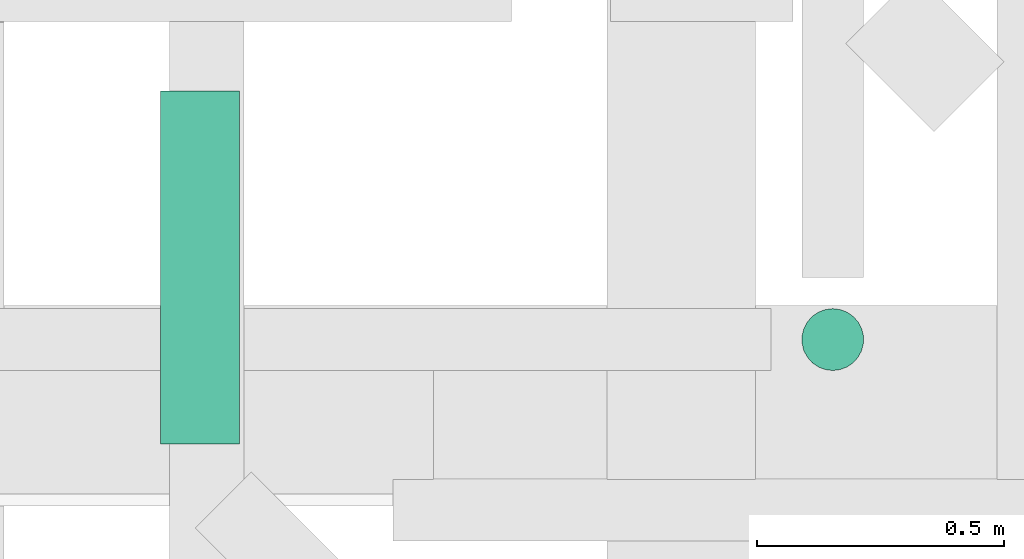
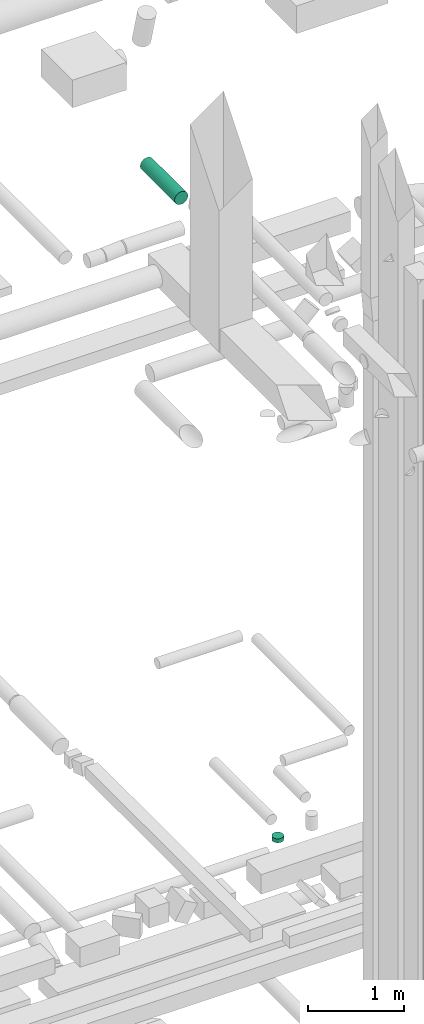
# One storey, part 283 of 337: 2 flow segments.
"""IFC2X3 building model written with IfcOpenShell, lengths in millimetres."""

from ifc_helpers import new_model, entity, si_unit, converted_unit, derived_unit, direction, frame, origin, origin_2d_with_axis, place, context, subcontext, project, spatial, circle, extrude, type_object, element, save


model = new_model("IFC2X3")

# Units and contexts
model_context = context("Model", 3, precision=0.01, world=origin(), true_north=direction((6.12303176911189e-17, 1.0)))
body_context = subcontext(model_context, "Body", "Model", "MODEL_VIEW")
ifc_project = project(units=[si_unit("LENGTHUNIT", "METRE", prefix="MILLI"), si_unit("AREAUNIT", "SQUARE_METRE"), si_unit("VOLUMEUNIT", "CUBIC_METRE"), converted_unit("PLANEANGLEUNIT", "DEGREE", entity("IfcRatioMeasure", 0.0174532925199433), si_unit("PLANEANGLEUNIT", "RADIAN"), dimensions=[0, 0, 0, 0, 0, 0, 0]), si_unit("MASSUNIT", "GRAM", prefix="KILO"), derived_unit("MASSDENSITYUNIT", [(si_unit("MASSUNIT", "GRAM", prefix="KILO"), 1), (si_unit("LENGTHUNIT", "METRE"), -3)]), derived_unit("MOMENTOFINERTIAUNIT", [(si_unit("LENGTHUNIT", "METRE"), 4)]), si_unit("TIMEUNIT", "SECOND"), si_unit("FREQUENCYUNIT", "HERTZ"), si_unit("THERMODYNAMICTEMPERATUREUNIT", "DEGREE_CELSIUS"), derived_unit("THERMALTRANSMITTANCEUNIT", [(si_unit("MASSUNIT", "GRAM", prefix="KILO"), 1), (si_unit("THERMODYNAMICTEMPERATUREUNIT", "KELVIN"), -1), (si_unit("TIMEUNIT", "SECOND"), -3)]), derived_unit("VOLUMETRICFLOWRATEUNIT", [(si_unit("LENGTHUNIT", "METRE"), 3), (si_unit("TIMEUNIT", "SECOND"), -1)]), derived_unit("MASSFLOWRATEUNIT", [(si_unit("MASSUNIT", "GRAM", prefix="KILO"), 1), (si_unit("TIMEUNIT", "SECOND"), -1)]), derived_unit("ROTATIONALFREQUENCYUNIT", [(si_unit("TIMEUNIT", "SECOND"), -1)]), si_unit("ELECTRICCURRENTUNIT", "AMPERE"), si_unit("ELECTRICVOLTAGEUNIT", "VOLT"), si_unit("POWERUNIT", "WATT"), si_unit("FORCEUNIT", "NEWTON", prefix="KILO"), si_unit("ILLUMINANCEUNIT", "LUX"), si_unit("LUMINOUSFLUXUNIT", "LUMEN"), si_unit("LUMINOUSINTENSITYUNIT", "CANDELA"), derived_unit("USERDEFINED", [(si_unit("MASSUNIT", "GRAM", prefix="KILO"), -1), (si_unit("LENGTHUNIT", "METRE"), -2), (si_unit("TIMEUNIT", "SECOND"), 3), (si_unit("LUMINOUSFLUXUNIT", "LUMEN"), 1)]), derived_unit("LINEARVELOCITYUNIT", [(si_unit("LENGTHUNIT", "METRE"), 1), (si_unit("TIMEUNIT", "SECOND"), -1)]), si_unit("PRESSUREUNIT", "PASCAL"), derived_unit("USERDEFINED", [(si_unit("LENGTHUNIT", "METRE"), -2), (si_unit("MASSUNIT", "GRAM", prefix="KILO"), 1), (si_unit("TIMEUNIT", "SECOND"), -2)]), derived_unit("LINEARFORCEUNIT", [(si_unit("MASSUNIT", "GRAM", prefix="KILO"), 1), (si_unit("LENGTHUNIT", "METRE"), 1), (si_unit("TIMEUNIT", "SECOND"), -2), (si_unit("LENGTHUNIT", "METRE"), -1)]), derived_unit("PLANARFORCEUNIT", [(si_unit("MASSUNIT", "GRAM", prefix="KILO"), 1), (si_unit("LENGTHUNIT", "METRE"), 1), (si_unit("TIMEUNIT", "SECOND"), -2), (si_unit("LENGTHUNIT", "METRE"), -2)])], contexts=[model_context])

# Site, building, storey
site_placement = place(None, origin())
site = spatial("IfcSite", under=ifc_project, at=site_placement, CompositionType="ELEMENT")
building_placement = place(site_placement, origin())
building = spatial("IfcBuilding", under=site, at=building_placement, CompositionType="ELEMENT")
storey_placement = place(building_placement, origin())
storey = spatial("IfcBuildingStorey", under=building, at=storey_placement, CompositionType="ELEMENT", Elevation=0.0)

# Flow segments
duct_segment_type = type_object("IfcDuctSegmentType", PredefinedType="NOTDEFINED")
flow_segment_1_placement = place(storey_placement, frame((52075.86, 16067.41, 18975.0)))
element("IfcFlowSegment", 1, at=flow_segment_1_placement, inside=storey, type_object=duct_segment_type, context=body_context, shape_type="SweptSolid", body=[
    extrude(circle(Radius=62.5, at=origin_2d_with_axis()), frame((64.1, 64.1, 0.0), z_axis=(0.0, 0.0, 1.0), x_axis=(0.0, 1.0, 0.0)), (0.0, 0.0, 1.0), 49.9997977063078),
])
flow_segment_2_placement = place(storey_placement, frame((50779.47, 15920.52, 27598.4)))
element("IfcFlowSegment", 2, at=flow_segment_2_placement, inside=storey, type_object=duct_segment_type, context=body_context, shape_type="SweptSolid", body=[
    extrude(circle(Radius=80.0, at=origin_2d_with_axis()), frame((81.6, 0.0, 81.6), z_axis=(0.0, 1.0, 0.0), x_axis=(1.0, 0.0, 0.0)), (0.0, 0.0, 1.0), 713.725830020301),
])

save(model, "model.ifc")
